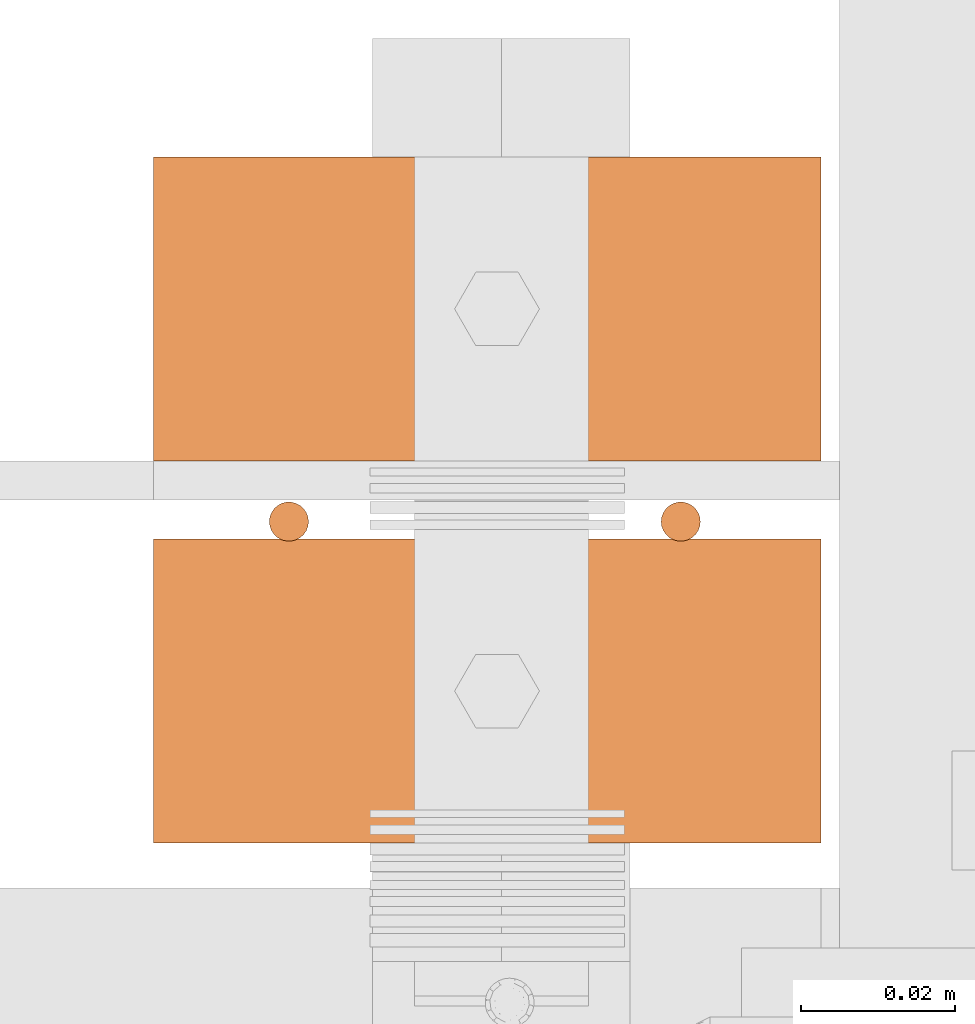
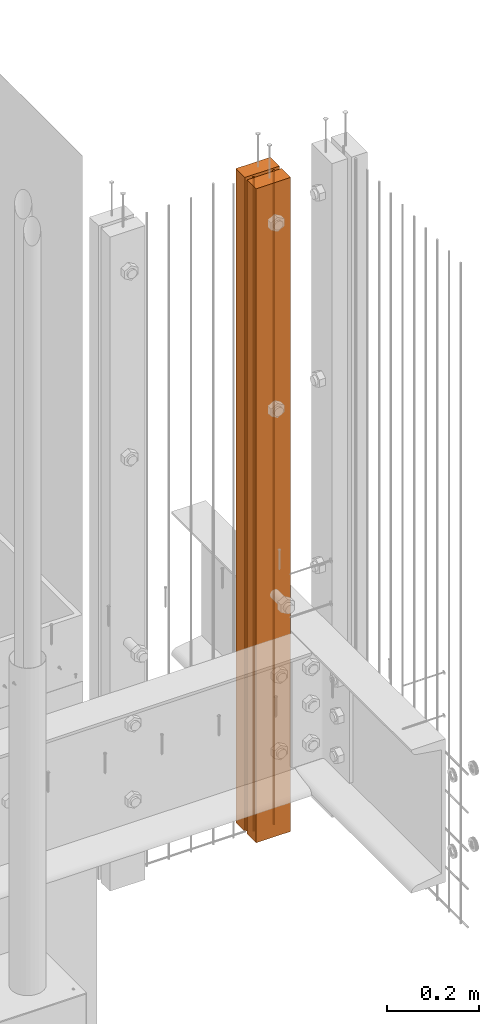
# One storey, part 13 of 44: 3 proxies.
"""IFC4 building model written with IfcOpenShell, lengths in feet."""

from ifc_helpers import new_model, entity, si_unit, converted_unit, derived_unit, direction, frame, frame_2d, origin, origin_2d_with_axis, place, context, subcontext, project, spatial, rectangle, circle, extrude, source, transform, mapped, material, type_object, type_shapes, element, save


model = new_model("IFC4")

# Units and contexts
model_context = context("Model", 3, precision=0.0001, world=origin(), true_north=direction((6.12303176911189e-17, 1.0)))
body_context = subcontext(model_context, "Body", "Model", "MODEL_VIEW")
ifc_project = project(units=[converted_unit("LENGTHUNIT", "FOOT", entity("IfcRatioMeasure", 0.3048), si_unit("LENGTHUNIT", "METRE"), dimensions=[1, 0, 0, 0, 0, 0, 0]), converted_unit("AREAUNIT", "SQUARE FOOT", entity("IfcRatioMeasure", 0.09290304), si_unit("AREAUNIT", "SQUARE_METRE"), dimensions=[2, 0, 0, 0, 0, 0, 0]), converted_unit("VOLUMEUNIT", "CUBIC FOOT", entity("IfcRatioMeasure", 0.028316846592), si_unit("VOLUMEUNIT", "CUBIC_METRE"), dimensions=[3, 0, 0, 0, 0, 0, 0]), converted_unit("PLANEANGLEUNIT", "DEGREE", entity("IfcRatioMeasure", 0.0174532925199433), si_unit("PLANEANGLEUNIT", "RADIAN"), dimensions=[0, 0, 0, 0, 0, 0, 0]), si_unit("MASSUNIT", "GRAM", prefix="KILO"), derived_unit("MASSDENSITYUNIT", [(si_unit("MASSUNIT", "GRAM", prefix="KILO"), 1), (si_unit("LENGTHUNIT", "METRE"), -3)]), derived_unit("MOMENTOFINERTIAUNIT", [(si_unit("LENGTHUNIT", "METRE"), 4)]), si_unit("TIMEUNIT", "SECOND"), si_unit("FREQUENCYUNIT", "HERTZ"), si_unit("THERMODYNAMICTEMPERATUREUNIT", "DEGREE_CELSIUS"), derived_unit("THERMALTRANSMITTANCEUNIT", [(si_unit("MASSUNIT", "GRAM", prefix="KILO"), 1), (si_unit("THERMODYNAMICTEMPERATUREUNIT", "KELVIN"), -1), (si_unit("TIMEUNIT", "SECOND"), -3)]), derived_unit("VOLUMETRICFLOWRATEUNIT", [(si_unit("LENGTHUNIT", "METRE"), 3), (si_unit("TIMEUNIT", "SECOND"), -1)]), si_unit("ELECTRICCURRENTUNIT", "AMPERE"), si_unit("ELECTRICVOLTAGEUNIT", "VOLT"), si_unit("POWERUNIT", "WATT"), si_unit("FORCEUNIT", "NEWTON"), si_unit("ILLUMINANCEUNIT", "LUX"), si_unit("LUMINOUSFLUXUNIT", "LUMEN"), si_unit("LUMINOUSINTENSITYUNIT", "CANDELA"), derived_unit("USERDEFINED", [(si_unit("MASSUNIT", "GRAM", prefix="KILO"), -1), (si_unit("LENGTHUNIT", "METRE"), -2), (si_unit("TIMEUNIT", "SECOND"), 3), (si_unit("LUMINOUSFLUXUNIT", "LUMEN"), 1)]), derived_unit("LINEARVELOCITYUNIT", [(si_unit("LENGTHUNIT", "METRE"), 1), (si_unit("TIMEUNIT", "SECOND"), -1)]), si_unit("PRESSUREUNIT", "PASCAL"), derived_unit("USERDEFINED", [(si_unit("LENGTHUNIT", "METRE"), -2), (si_unit("MASSUNIT", "GRAM", prefix="KILO"), 1), (si_unit("TIMEUNIT", "SECOND"), -2)]), derived_unit("LINEARFORCEUNIT", [(si_unit("MASSUNIT", "GRAM", prefix="KILO"), 1), (si_unit("LENGTHUNIT", "METRE"), 1), (si_unit("TIMEUNIT", "SECOND"), -2), (si_unit("LENGTHUNIT", "METRE"), -1)]), derived_unit("PLANARFORCEUNIT", [(si_unit("MASSUNIT", "GRAM", prefix="KILO"), 1), (si_unit("LENGTHUNIT", "METRE"), 1), (si_unit("TIMEUNIT", "SECOND"), -2), (si_unit("LENGTHUNIT", "METRE"), -2)])], contexts=[model_context])

# Site, building, storey
site_placement = place(None, origin())
site = spatial("IfcSite", under=ifc_project, at=site_placement, CompositionType="ELEMENT")
building_placement = place(site_placement, origin())
building = spatial("IfcBuilding", under=site, at=building_placement, CompositionType="ELEMENT")
storey_placement = place(building_placement, origin())
storey = spatial("IfcBuildingStorey", under=building, at=storey_placement, CompositionType="ELEMENT", Elevation=0.0)

# Proxies
ifc_material_1 = material(Name="(2) 2X4s - EXT STAIN - DARK", Category="Materials")
building_element_proxy_type_1 = type_object("IfcBuildingElementProxyType", Name="RAILING 19:RAILING 2", PredefinedType="NOTDEFINED", material=ifc_material_1)
shared_shape_1 = source(origin(), body_context, "Body", "SweptSolid", [
    extrude(rectangle(XDim=0.283998557910536, YDim=0.129166666666605, at=frame_2d((1.13686837721616e-13, -4.44089209850063e-16), x_axis=(1.0, 0.0))), frame((0.141999278955154, 0.227083333333212, 0.0), z_axis=(0.0, 0.0, 1.0), x_axis=(-1.0, 0.0, 0.0)), (0.0, 0.0, 1.0), 5.70833333332643),
    extrude(rectangle(XDim=0.129166666666606, YDim=0.283998557910536, at=frame_2d((0.0, -1.13686837721616e-13), x_axis=(1.0, 0.0))), frame((0.141999278954927, 0.0645833333333039, 0.0), z_axis=(0.0, 0.0, 1.0), x_axis=(0.0, 1.0, 0.0)), (0.0, 0.0, 1.0), 5.70833333332643),
])
type_shapes(building_element_proxy_type_1, [shared_shape_1])
proxy_1_placement = place(storey_placement, frame((1493.71728937919, 4.7578722552008, 8.17708333334024)))
element("IfcBuildingElementProxy", 1, at=proxy_1_placement, inside=storey, type_object=building_element_proxy_type_1, material=ifc_material_1, Name="RAILING 19:RAILING 2", ObjectType="RAILING 19:RAILING 2", PredefinedType="NOTDEFINED", context=body_context, shape_type="MappedRepresentation", body=[
    mapped(shared_shape_1, transform((0.0, 0.0, 0.0), scale=1.0)),
])
ifc_material_2 = material(Category="Materials")
building_element_proxy_type_2 = type_object("IfcBuildingElementProxyType", Name="RAILING 39:RAILING 20", PredefinedType="NOTDEFINED", material=ifc_material_2)
shared_shape_2 = source(origin(), body_context, "Body", "SweptSolid", [
    extrude(circle(Radius=0.00833333333333333, at=origin_2d_with_axis()), frame((0.013567166128496, 0.0135671661283334, 0.0)), (0.0, 0.0, 1.0), 5.70833333333333),
])
type_shapes(building_element_proxy_type_2, [shared_shape_2])
proxy_2_placement = place(storey_placement, frame((1493.76130778512, 4.88094253557483, 8.17708333333334)))
element("IfcBuildingElementProxy", 2, at=proxy_2_placement, inside=storey, type_object=building_element_proxy_type_2, material=ifc_material_2, Name="RAILING 39:RAILING 20", ObjectType="RAILING 39:RAILING 20", PredefinedType="NOTDEFINED", context=body_context, shape_type="MappedRepresentation", body=[
    mapped(shared_shape_2, transform((0.0, 0.0, 0.0), scale=1.0)),
])
building_element_proxy_type_3 = type_object("IfcBuildingElementProxyType", Name="RAILING 40:RAILING 20", PredefinedType="NOTDEFINED", material=ifc_material_2)
shared_shape_3 = source(origin(), body_context, "Body", "SweptSolid", [
    extrude(circle(Radius=0.00833333333333333, at=origin_2d_with_axis()), frame((0.013567166128496, 0.0135671661283334, 0.0)), (0.0, 0.0, 1.0), 5.70833333333333),
])
type_shapes(building_element_proxy_type_3, [shared_shape_3])
proxy_3_placement = place(storey_placement, frame((1493.92797445179, 4.88094253557483, 8.17708333333334)))
element("IfcBuildingElementProxy", 3, at=proxy_3_placement, inside=storey, type_object=building_element_proxy_type_3, material=ifc_material_2, Name="RAILING 40:RAILING 20", ObjectType="RAILING 40:RAILING 20", PredefinedType="NOTDEFINED", context=body_context, shape_type="MappedRepresentation", body=[
    mapped(shared_shape_3, transform((0.0, 0.0, 0.0), scale=1.0)),
])

save(model, "model.ifc")
